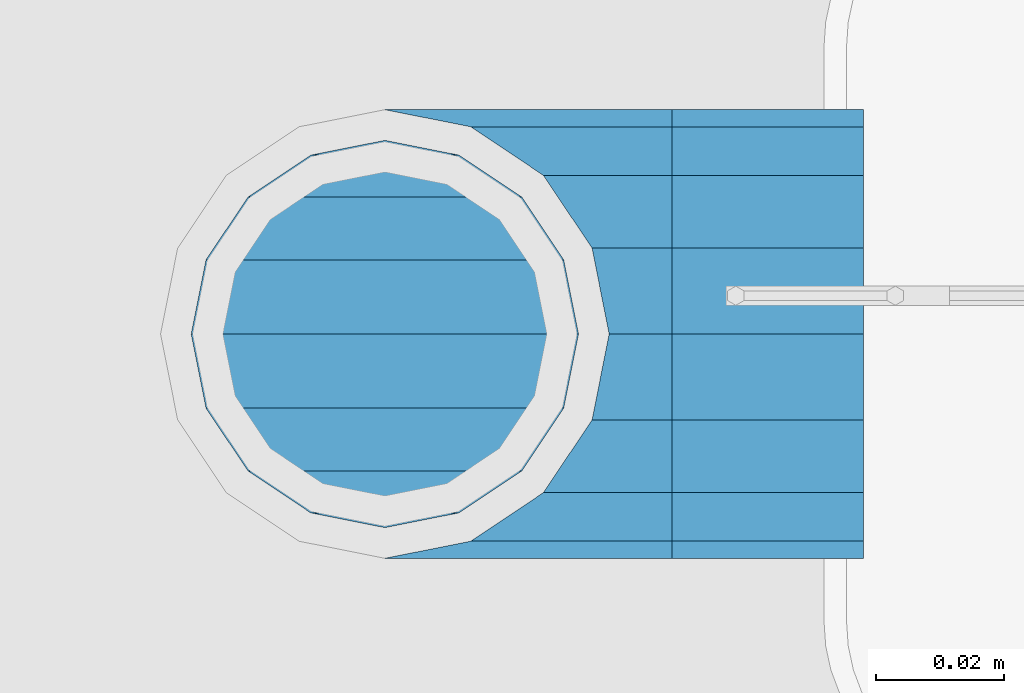
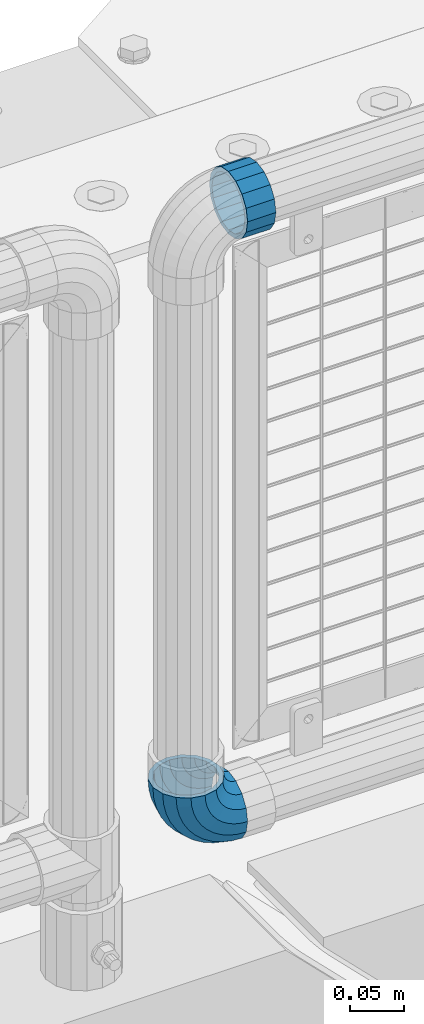
# One storey, part 164 of 242: 1 beam, 1 member.
"""IFC2X3 building model written with IfcOpenShell, lengths in millimetres."""

from ifc_helpers import new_model, si_unit, frame, origin_with_axes, place, context, subcontext, project, spatial, faceted_brep, material, type_object, element, save


model = new_model("IFC2X3")

# Units and contexts
model_context = context("Model", 3, precision=1e-05, world=origin_with_axes())
body_context = subcontext(model_context, "Body", "Model", "MODEL_VIEW")
ifc_project = project(units=[si_unit("LENGTHUNIT", "METRE", prefix="MILLI"), si_unit("AREAUNIT", "SQUARE_METRE"), si_unit("VOLUMEUNIT", "CUBIC_METRE"), si_unit("MASSUNIT", "GRAM", prefix="KILO"), si_unit("TIMEUNIT", "SECOND"), si_unit("PLANEANGLEUNIT", "RADIAN"), si_unit("SOLIDANGLEUNIT", "STERADIAN"), si_unit("THERMODYNAMICTEMPERATUREUNIT", "DEGREE_CELSIUS"), si_unit("LUMINOUSINTENSITYUNIT", "LUMEN")], contexts=[model_context])

# Site, building, storey
site_placement = place(None, origin_with_axes())
site = spatial("IfcSite", under=ifc_project, at=site_placement, CompositionType="ELEMENT")
building_placement = place(site_placement, origin_with_axes())
building = spatial("IfcBuilding", under=site, at=building_placement, Name="Standard", CompositionType="ELEMENT")
storey_placement = place(building_placement, origin_with_axes())
storey = spatial("IfcBuildingStorey", under=building, at=storey_placement, Name="Undefined", CompositionType="ELEMENT", Elevation=0.0)

# Beam
ifc_material = material(Name="Misc_Undefined")
beam_type = type_object("IfcBeamType", PredefinedType="NOTDEFINED")
beam_placement = place(storey_placement, frame((-23710.39, -19335.5, 969.849999999999), z_axis=(0.0, 0.0, 1.0), x_axis=(1.0, 0.0, 0.0)))
element("IfcBeam", 1, at=beam_placement, inside=storey, type_object=beam_type, material=ifc_material, context=body_context, shape_type="Brep", body=[
    faceted_brep([(0.0, -30.3499999999985, 0.0), (0.0, -28.0397438117179, 11.6144421722784), (30.0, -28.0397438117179, 11.6144421722805), (30.0, -30.3499999999985, 0.0), (0.0, -21.46069080901, 21.4606908090136), (30.0, -21.46069080901, 21.4606908090117), (0.0, -11.614442172282, 28.0397438117143), (30.0, -11.614442172282, 28.0397438117176), (0.0, 0.0, 30.3499999999985), (30.0, 0.0, 30.35), (0.0, 11.614442172282, 28.0397438117143), (30.0, 11.614442172282, 28.0397438117176), (0.0, 21.46069080901, 21.4606908090136), (30.0, 21.46069080901, 21.4606908090117), (0.0, 28.0397438117179, 11.6144421722784), (30.0, 28.0397438117179, 11.6144421722805), (0.0, 30.3499999999985, 0.0), (30.0, 30.3499999999985, 0.0), (0.0, 28.0397438117179, -11.6144421722784), (30.0, 28.0397438117179, -11.6144421722805), (0.0, 21.46069080901, -21.4606908090136), (30.0, 21.46069080901, -21.4606908090117), (0.0, 11.614442172282, -28.0397438117143), (30.0, 11.614442172282, -28.0397438117176), (0.0, 0.0, -30.3499999999985), (30.0, 0.0, -30.35), (0.0, -11.614442172282, -28.0397438117143), (30.0, -11.614442172282, -28.0397438117176), (0.0, -21.46069080901, -21.4606908090136), (30.0, -21.46069080901, -21.4606908090117), (0.0, -28.0397438117179, -11.6144421722784), (30.0, -28.0397438117179, -11.6144421722805), (0.0, -35.1500000000015, 0.0), (0.0, -32.4743655677703, -13.4513226476338), (30.0, -32.4743655677703, -13.4513226476329), (30.0, -35.1500000000015, 0.0), (0.0, -24.8548033587067, -24.8548033587067), (30.0, -24.8548033587067, -24.8548033587072), (0.0, -13.4513226476338, -32.4743655677739), (30.0, -13.4513226476338, -32.4743655677718), (0.0, 0.0, -35.1500000000015), (30.0, 0.0, -35.15), (0.0, 13.4513226476338, -32.4743655677739), (30.0, 13.4513226476338, -32.4743655677718), (0.0, 24.8548033587067, -24.8548033587067), (30.0, 24.8548033587067, -24.8548033587072), (0.0, 32.4743655677703, -13.4513226476338), (30.0, 32.4743655677703, -13.4513226476329), (0.0, 35.1500000000015, 0.0), (30.0, 35.1500000000015, 0.0), (0.0, 32.4743655677703, 13.4513226476338), (30.0, 32.4743655677703, 13.4513226476329), (0.0, 24.8548033587067, 24.8548033587067), (30.0, 24.8548033587067, 24.8548033587072), (0.0, 13.4513226476338, 32.4743655677739), (30.0, 13.4513226476338, 32.4743655677718), (0.0, 0.0, 35.1500000000015), (30.0, 0.0, 35.15), (0.0, -13.4513226476338, 32.4743655677739), (30.0, -13.4513226476338, 32.4743655677718), (0.0, -24.8548033587067, 24.8548033587067), (30.0, -24.8548033587067, 24.8548033587072), (0.0, -32.4743655677703, 13.4513226476338), (30.0, -32.4743655677703, 13.4513226476329)], [[[0, 1, 2, 3]], [[1, 4, 5, 2]], [[4, 6, 7, 5]], [[6, 8, 9, 7]], [[8, 10, 11, 9]], [[10, 12, 13, 11]], [[12, 14, 15, 13]], [[14, 16, 17, 15]], [[16, 18, 19, 17]], [[18, 20, 21, 19]], [[20, 22, 23, 21]], [[22, 24, 25, 23]], [[24, 26, 27, 25]], [[26, 28, 29, 27]], [[28, 30, 31, 29]], [[30, 0, 3, 31]], [[32, 33, 34, 35]], [[33, 36, 37, 34]], [[36, 38, 39, 37]], [[38, 40, 41, 39]], [[40, 42, 43, 41]], [[42, 44, 45, 43]], [[44, 46, 47, 45]], [[46, 48, 49, 47]], [[48, 50, 51, 49]], [[50, 52, 53, 51]], [[52, 54, 55, 53]], [[54, 56, 57, 55]], [[56, 58, 59, 57]], [[58, 60, 61, 59]], [[60, 62, 63, 61]], [[62, 32, 35, 63]], [[37, 39, 41, 43, 45, 47, 49, 51, 53, 55, 57, 59, 61, 63, 35, 34], [5, 7, 9, 11, 13, 15, 17, 19, 21, 23, 25, 27, 29, 31, 3, 2]], [[62, 60, 58, 56, 54, 52, 50, 48, 46, 44, 42, 40, 38, 36, 33, 32], [30, 28, 26, 24, 22, 20, 18, 16, 14, 12, 10, 8, 6, 4, 1, 0]]]),
])

# Member
member_type = type_object("IfcMemberType", PredefinedType="NOTDEFINED")
member_placement = place(storey_placement, frame((-23755.39, -19335.5, 343.170000000002), z_axis=(-0.707106781186548, 0.0, -0.707106781186548), x_axis=(0.707106781186548, 0.0, -0.707106781186548)))
element("IfcMember", 2, at=member_placement, inside=storey, type_object=member_type, material=ifc_material, context=body_context, shape_type="Brep", body=[
    faceted_brep([(0.0, -35.1500000000015, 0.0), (9.51152146006643, -32.4743655677703, -9.51152146006643), (13.2759578763398, -32.4743655677703, -6.29638902527768), (5.36946880023243, -35.1500000000015, 4.58595959347804), (17.5749999999971, -24.8548033587067, -17.5749999999971), (19.978755663109, -24.8548033587067, -15.5219987155633), (22.9628441077002, -13.4513226476338, -22.9628441077002), (24.4574219585229, -13.4513226476338, -21.6863540323939), (24.8548033587067, 0.0, -24.8548033587067), (26.0301204183124, 0.0, -23.8509877588003), (22.9628441077002, 13.4513226476338, -22.9628441077002), (24.4574219585229, 13.4513226476338, -21.6863540323939), (17.5749999999971, 24.8548033587067, -17.5749999999971), (19.978755663109, 24.8548033587067, -15.5219987155633), (9.51152146006643, 32.4743655677703, -9.51152146006643), (13.2759578763398, 32.4743655677703, -6.29638902527768), (0.0, 35.1500000000015, 0.0), (5.36946880023243, 35.1500000000015, 4.58595959347804), (-9.51152146007371, 32.4743655677703, 9.51152146007371), (-2.53702027587133, 32.4743655677703, 15.4683082122338), (-17.5750000000007, 24.8548033587067, 17.5750000000007), (-9.23981806264783, 24.8548033587067, 24.6939179025212), (-22.9628441077039, 13.4513226476338, 22.9628441077039), (-13.718484358058, 13.4513226476338, 30.8582732193499), (-24.8548033587103, 0.0, 24.8548033587103), (-15.2911828178512, 0.0, 33.02290694576), (-22.9628441077039, -13.4513226476338, 22.9628441077039), (-13.718484358058, -13.4513226476338, 30.8582732193499), (-17.5750000000007, -24.8548033587067, 17.5750000000007), (-9.23981806264783, -24.8548033587067, 24.6939179025212), (-9.51152146007371, -32.4743655677703, 9.51152146007371), (-2.53702027587133, -32.4743655677703, 15.4683082122338), (0.0, -30.3499999999985, 0.0), (-8.2126508197216, -28.0397438117179, 8.2126508197216), (-1.45732902223972, -28.0397438117179, 13.9822406910389), (5.36946880023243, -30.3499999999985, 4.58595959347804), (-15.1749999999993, -21.46069080901, 15.1750000000029), (-7.24480876131565, -21.46069080901, 21.9480231689959), (-19.827092992, -11.614442172282, 19.827092992), (-11.1118790903529, -11.614442172282, 27.2705888550809), (-21.4606908090136, 0.0, 21.4606908090136), (-12.4698136068437, 0.0, 29.1396253727598), (-19.827092992, 11.614442172282, 19.827092992), (-11.1118790903529, 11.614442172282, 27.2705888550809), (-15.1749999999993, 21.46069080901, 15.1750000000029), (-7.24480876131565, 21.46069080901, 21.9480231689959), (-8.2126508197216, 28.0397438117179, 8.2126508197216), (-1.45732902223972, 28.0397438117179, 13.9822406910389), (0.0, 30.3499999999985, 0.0), (5.36946880023243, 30.3499999999985, 4.58595959347804), (8.21265081971796, 28.0397438117179, -8.21265081971796), (12.1962666227009, 28.0397438117179, -4.81032150407918), (15.1749999999956, 21.46069080901, -15.1749999999956), (17.9837463617769, 21.46069080901, -12.776103982038), (19.8270929919963, 11.614442172282, -19.8270929919963), (21.8508166908177, 11.614442172282, -18.0986696681193), (21.46069080901, 0.0, -21.46069080901), (23.2087512073085, 0.0, -19.9677061858001), (19.8270929919963, -11.614442172282, -19.8270929919963), (21.8508166908177, -11.614442172282, -18.0986696681193), (15.1749999999956, -21.46069080901, -15.1749999999956), (17.9837463617769, -21.46069080901, -12.776103982038), (8.21265081971796, -28.0397438117179, -8.21265081971796), (12.1962666227009, -28.0397438117179, -4.81032150407918), (17.4970053560683, -32.4743655677703, -3.70972780291959), (11.3902326651114, -35.1500000000015, 8.27548843508339), (22.6740772628618, -24.8548033587067, -13.870303514941), (26.1332861179508, -13.4513226476338, -20.6593831546816), (27.3479987309584, 0.0, -23.0433908901377), (26.1332861179508, 13.4513226476338, -20.6593831546816), (22.6740772628618, 24.8548033587067, -13.870303514941), (17.4970053560683, 32.4743655677703, -3.70972780291959), (11.3902326651114, 35.1500000000015, 8.27548843508339), (5.28345997415818, 32.4743655677703, 20.2607046730864), (0.106388067368243, 24.8548033587067, 30.4212803851133), (-3.35282078772798, 13.4513226476338, 37.2103600248483), (-4.56753340073192, 0.0, 39.5943677603045), (-3.35282078772798, -13.4513226476338, 37.2103600248483), (0.106388067368243, -24.8548033587067, 30.4212803851133), (5.28345997415818, -32.4743655677703, 20.2607046730864), (6.11738625912403, -28.0397438117179, 18.6240321853948), (11.3902326651114, -30.3499999999985, 8.27548843508339), (1.6472829199738, -21.46069080901, 27.3971039595017), (-1.3395446405375, -11.614442172282, 33.2590831078942), (-2.38837900198268, 0.0, 35.3175364441995), (-1.3395446405375, 11.614442172282, 33.2590831078942), (1.6472829199738, 21.46069080901, 27.3971039595017), (6.11738625912403, 28.0397438117179, 18.6240321853948), (11.3902326651114, 30.3499999999985, 8.27548843508339), (16.6630790711024, 28.0397438117179, -2.07305531522434), (21.1331824102526, 21.46069080901, -10.8461270893331), (24.1200099707639, 11.614442172282, -16.7081062377274), (25.1688443322091, 0.0, -18.7665595740364), (24.1200099707639, -11.614442172282, -16.7081062377274), (21.1331824102526, -21.46069080901, -10.8461270893331), (16.6630790711024, -28.0397438117179, -2.07305531522434), (22.070727701459, -32.4743655677703, -1.81522997692991), (17.9140404065183, -35.1500000000015, 10.9777380798896), (25.5945970362081, -24.8548033587067, -12.6605846156453), (27.9491712485069, -13.4513226476338, -19.9072189058916), (28.7759877587996, 0.0, -22.4518984678853), (27.9491712485069, 13.4513226476338, -19.9072189058916), (25.5945970362081, 24.8548033587067, -12.6605846156453), (22.070727701459, 32.4743655677703, -1.81522997692991), (17.9140404065183, 35.1500000000015, 10.9777380798896), (13.7573531115813, 32.4743655677703, 23.7707061367073), (10.2334837768321, 24.8548033587067, 34.6160607754227), (7.87890956453339, 13.4513226476338, 41.862695065669), (7.05209305424069, 0.0, 44.4073746276626), (7.87890956453339, -13.4513226476338, 41.862695065669), (10.2334837768321, -24.8548033587067, 34.6160607754227), (13.7573531115813, -32.4743655677703, 23.7707061367073), (14.3249803951003, -28.0397438117179, 22.0237289909674), (17.9140404065183, -30.3499999999985, 10.9777380798896), (11.2823222355109, -21.46069080901, 31.3880679179947), (9.24928305077992, -11.614442172282, 37.6451191472697), (8.53537462723762, 0.0, 39.8423033494473), (9.24928305077992, 11.614442172282, 37.6451191472697), (11.2823222355109, 21.46069080901, 31.3880679179947), (14.3249803951003, 28.0397438117179, 22.0237289909674), (17.9140404065183, 30.3499999999985, 10.9777380798896), (21.50310041794, 28.0397438117179, -0.0682528311899659), (24.5457585775293, 21.46069080901, -9.43259175821731), (26.5787977622604, 11.614442172282, -15.6896429874923), (27.2927061858027, 0.0, -17.8868271896699), (26.5787977622604, -11.614442172282, -15.6896429874923), (24.5457585775293, -21.46069080901, -9.43259175821731), (21.50310041794, -28.0397438117179, -0.0682528311899659), (26.8845046890456, -32.4743655677703, -0.659544371261291), (24.7802542265854, -35.1500000000015, 12.6261701733874), (28.6684020936846, -24.8548033587067, -11.9226293117918), (29.8603642316994, -13.4513226476338, -19.4483820661244), (30.2789256727447, 0.0, -22.0910749985305), (29.8603642316994, 13.4513226476338, -19.4483820661244), (28.6684020936846, 24.8548033587067, -11.9226293117918), (26.8845046890456, 32.4743655677703, -0.659544371261291), (24.7802542265854, 35.1500000000015, 12.6261701733874), (22.6760037641179, 32.4743655677703, 25.911884718038), (20.8921063594826, 24.8548033587067, 37.1749696585684), (19.7001442214641, 13.4513226476338, 44.7007224129011), (19.2815827804188, 0.0, 47.3434153453072), (19.7001442214641, -13.4513226476338, 44.7007224129011), (20.8921063594826, -24.8548033587067, 37.1749696585684), (22.6760037641179, -32.4743655677703, 25.911884718038), (22.963355178621, -28.0397438117179, 24.0976192894668), (24.7802542265854, -30.3499999999985, 12.6261701733874), (21.4230625404816, -21.46069080901, 33.8226442665673), (20.3938719035323, -11.614442172282, 40.3206982094944), (20.032468212612, 0.0, 42.6025113104497), (20.3938719035323, 11.614442172282, 40.3206982094944), (21.4230625404816, 21.46069080901, 33.8226442665673), (22.963355178621, 28.0397438117179, 24.0976192894668), (24.7802542265854, 30.3499999999985, 12.6261701733874), (26.5971532745461, 28.0397438117179, 1.15472105730987), (28.1374459126855, 21.46069080901, -8.5703039197906), (29.1666365496349, 11.614442172282, -15.0683578627177), (29.5280402405515, 0.0, -17.350170963673), (29.1666365496349, -11.614442172282, -15.0683578627177), (28.1374459126855, -21.46069080901, -8.5703039197906), (26.5971532745461, -28.0397438117179, 1.15472105730987), (31.8198051533909, -32.4743655677703, -0.271127801024704), (31.8198051533909, -35.1500000000015, 13.1801948466091), (31.8198051533946, -24.8548033587067, -11.6746085121031), (31.8198051533909, -13.4513226476338, -19.2941707211648), (31.8198051533909, 0.0, -21.9698051533924), (31.8198051533909, 13.4513226476338, -19.2941707211648), (31.8198051533946, 24.8548033587067, -11.6746085121031), (31.8198051533909, 32.4743655677703, -0.271127801024704), (31.8198051533909, 35.1500000000015, 13.1801948466091), (31.8198051533909, 32.4743655677703, 26.6315174942411), (31.8198051533909, 24.8548033587067, 38.0349982053158), (31.8198051533909, 13.4513226476338, 45.6545604143812), (31.8198051533946, 0.0, 48.3301948466051), (31.8198051533909, -13.4513226476338, 45.6545604143812), (31.8198051533909, -24.8548033587067, 38.0349982053158), (31.8198051533909, -32.4743655677703, 26.6315174942411), (31.8198051533909, -28.0397438117179, 24.7946370188874), (31.8198051533909, -30.3499999999985, 13.1801948466091), (31.8198051533946, -21.46069080901, 34.6408856556172), (31.8198051533946, -11.614442172282, 41.2199386583234), (31.8198051533909, 0.0, 43.5301948466076), (31.8198051533946, 11.614442172282, 41.2199386583234), (31.8198051533946, 21.46069080901, 34.6408856556172), (31.8198051533909, 28.0397438117179, 24.7946370188874), (31.8198051533909, 30.3499999999985, 13.1801948466091), (31.8198051533946, 28.0397438117179, 1.56575267432527), (31.8198051533909, 21.46069080901, -8.28049596240453), (31.8198051533946, 11.614442172282, -14.8595489651107), (31.8198051533909, 0.0, -17.1698051533913), (31.8198051533946, -11.614442172282, -14.8595489651107), (31.8198051533909, -21.46069080901, -8.28049596240453), (31.8198051533946, -28.0397438117179, 1.56575267432527), (36.7551056177363, -32.4743655677703, -0.659544371261291), (38.8593560802037, -35.1500000000015, 12.6261701733874), (34.9712082131009, -24.8548033587067, -11.9226293117899), (33.7792460750898, -13.4513226476338, -19.4483820661244), (33.3606846340372, 0.0, -22.0910749985305), (33.7792460750898, 13.4513226476338, -19.4483820661244), (34.9712082131009, 24.8548033587067, -11.9226293117899), (36.7551056177363, 32.4743655677703, -0.659544371261291), (38.8593560802037, 35.1500000000015, 12.6261701733874), (40.9636065426712, 32.4743655677703, 25.911884718038), (42.7475039473029, 24.8548033587067, 37.1749696585703), (43.9394660853177, 13.4513226476338, 44.7007224129011), (44.3580275263666, 0.0, 47.3434153453054), (43.9394660853177, -13.4513226476338, 44.7007224129011), (42.7475039473029, -24.8548033587067, 37.1749696585703), (40.9636065426712, -32.4743655677703, 25.911884718038), (40.6762551281645, -28.0397438117179, 24.097619289465), (38.8593560802037, -30.3499999999985, 12.6261701733874), (42.2165477663038, -21.46069080901, 33.8226442665655), (43.2457384032568, -11.614442172282, 40.3206982094944), (43.6071420941771, 0.0, 42.6025113104533), (43.2457384032568, 11.614442172282, 40.3206982094944), (42.2165477663038, 21.46069080901, 33.8226442665655), (40.6762551281645, 28.0397438117179, 24.097619289465), (38.8593560802037, 30.3499999999985, 12.6261701733874), (37.042457032243, 28.0397438117179, 1.15472105730987), (35.5021643941, 21.46069080901, -8.5703039197906), (34.4729737571543, 11.614442172282, -15.0683578627231), (34.1115700662303, 0.0, -17.350170963673), (34.4729737571543, -11.614442172282, -15.0683578627231), (35.5021643941, -21.46069080901, -8.5703039197906), (37.042457032243, -28.0397438117179, 1.15472105730987), (41.5688826053265, -32.4743655677703, -1.81522997693173), (45.7255699002671, -35.1500000000015, 10.9777380798896), (38.0450132705773, -24.8548033587067, -12.6605846156435), (35.6904390582749, -13.4513226476338, -19.9072189058897), (34.8636225479822, 0.0, -22.4518984678834), (35.6904390582749, 13.4513226476338, -19.9072189058897), (38.0450132705773, 24.8548033587067, -12.6605846156435), (41.5688826053265, 32.4743655677703, -1.81522997693173), (45.7255699002671, 35.1500000000015, 10.9777380798896), (49.8822571952041, 32.4743655677703, 23.7707061367091), (53.4061265299533, 24.8548033587067, 34.6160607754209), (55.7607007422557, 13.4513226476338, 41.8626950656671), (56.5875172525448, 0.0, 44.4073746276645), (55.7607007422557, -13.4513226476338, 41.8626950656671), (53.4061265299533, -24.8548033587067, 34.6160607754209), (49.8822571952041, -32.4743655677703, 23.7707061367091), (49.3146299116852, -28.0397438117179, 22.0237289909692), (45.7255699002671, -30.3499999999985, 10.9777380798896), (52.3572880712782, -21.46069080901, 31.3880679179947), (54.3903272560092, -11.614442172282, 37.6451191472679), (55.1042356795442, 0.0, 39.8423033494473), (54.3903272560092, 11.614442172282, 37.6451191472679), (52.3572880712782, 21.46069080901, 31.3880679179947), (49.3146299116852, 28.0397438117179, 22.0237289909692), (45.7255699002671, 30.3499999999985, 10.9777380798896), (42.1365098888455, 28.0397438117179, -0.0682528311917849), (39.0938517292525, 21.46069080901, -9.43259175821731), (37.0608125445215, 11.614442172282, -15.6896429874905), (36.3469041209864, 0.0, -17.8868271896699), (37.0608125445215, -11.614442172282, -15.6896429874905), (39.0938517292525, -21.46069080901, -9.43259175821731), (42.1365098888455, -28.0397438117179, -0.0682528311917849), (46.1426049507172, -32.4743655677703, -3.70972780292141), (52.2493776416704, -35.1500000000015, 8.27548843508339), (40.9655330439236, -24.8548033587067, -13.8703035149429), (37.5063241888347, -13.4513226476338, -20.6593831546797), (36.2916115758235, 0.0, -23.0433908901359), (37.5063241888347, 13.4513226476338, -20.6593831546797), (40.9655330439236, 24.8548033587067, -13.8703035149429), (46.1426049507172, 32.4743655677703, -3.70972780292141), (52.2493776416704, 35.1500000000015, 8.27548843508339), (58.3561503326309, 32.4743655677703, 20.26070467309), (63.5332222394209, 24.8548033587067, 30.4212803851133), (66.9924310945098, 13.4513226476338, 37.2103600248465), (68.2071437075174, 0.0, 39.5943677603027), (66.9924310945098, -13.4513226476338, 37.2103600248465), (63.5332222394209, -24.8548033587067, 30.4212803851133), (58.3561503326309, -32.4743655677703, 20.26070467309), (57.5222240476614, -28.0397438117179, 18.6240321853948), (52.2493776416704, -30.3499999999985, 8.27548843508339), (61.9923273868117, -21.46069080901, 27.3971039595035), (64.9791549473193, -11.614442172282, 33.259083107896), (66.0279893087682, 0.0, 35.3175364442013), (64.9791549473193, 11.614442172282, 33.259083107896), (61.9923273868117, 21.46069080901, 27.3971039595035), (57.5222240476614, 28.0397438117179, 18.6240321853948), (52.2493776416704, 30.3499999999985, 8.27548843508339), (46.9765312356831, 28.0397438117179, -2.07305531522616), (42.5064278965328, 21.46069080901, -10.8461270893349), (39.5196003360215, 11.614442172282, -16.7081062377292), (38.4707659745764, 0.0, -18.7665595740327), (39.5196003360215, -11.614442172282, -16.7081062377292), (42.5064278965328, -21.46069080901, -10.8461270893349), (46.9765312356831, -28.0397438117179, -2.07305531522616), (50.3636524304493, -32.4743655677703, -6.29638902527404), (58.2701415065567, -35.1500000000015, 4.58595959347986), (43.6608546436801, -24.8548033587067, -15.5219987155633), (39.1821883482626, -13.4513226476338, -21.686354032392), (37.609489888473, 0.0, -23.8509877587985), (39.1821883482626, 13.4513226476338, -21.686354032392), (43.6608546436801, 24.8548033587067, -15.5219987155633), (50.3636524304493, 32.4743655677703, -6.29638902527404), (58.2701415065567, 35.1500000000015, 4.58595959347986), (66.1766305826604, 32.4743655677703, 15.4683082122356), (72.8794283694297, 24.8548033587067, 24.6939179025212), (77.3580946648435, 13.4513226476338, 30.8582732193518), (78.9307931246331, 0.0, 33.02290694576), (77.3580946648435, -13.4513226476338, 30.8582732193518), (72.8794283694297, -24.8548033587067, 24.6939179025212), (66.1766305826604, -32.4743655677703, 15.4683082122356), (65.0969393290252, -28.0397438117179, 13.9822406910407), (58.2701415065567, -30.3499999999985, 4.58595959347986), (70.8844190681011, -21.46069080901, 21.9480231689959), (74.751489397142, -11.614442172282, 27.270588855079), (76.1094239136328, 0.0, 29.139625372758), (74.751489397142, 11.614442172282, 27.270588855079), (70.8844190681011, 21.46069080901, 21.9480231689959), (65.0969393290252, 28.0397438117179, 13.9822406910407), (58.2701415065567, 30.3499999999985, 4.58595959347986), (51.4433436840845, 28.0397438117179, -4.81032150407918), (45.655863945005, 21.46069080901, -12.7761039820361), (41.7887936159677, 11.614442172282, -18.0986696681175), (40.4308590994769, 0.0, -19.9677061858019), (41.7887936159677, -11.614442172282, -18.0986696681175), (45.655863945005, -21.46069080901, -12.7761039820361), (51.4433436840845, -28.0397438117179, -4.81032150407918), (54.1280888467154, -32.4743655677703, -9.51152146006643), (63.6396103067855, -35.1500000000015, 3.63797880709171e-12), (46.0646103067847, -24.8548033587067, -17.5749999999971), (40.6767661990853, -13.4513226476338, -22.9628441077002), (38.7848069480788, 0.0, -24.8548033587049), (40.6767661990853, 13.4513226476338, -22.9628441077002), (46.0646103067847, 24.8548033587067, -17.5749999999971), (54.1280888467154, 32.4743655677703, -9.51152146006643), (63.6396103067855, 35.1500000000015, 3.63797880709171e-12), (73.1511317668555, 32.4743655677703, 9.51152146007189), (81.2146103067862, 24.8548033587067, 17.5750000000025), (86.6024544144893, 13.4513226476338, 22.9628441077057), (88.4944136654922, 0.0, 24.8548033587103), (86.6024544144893, -13.4513226476338, 22.9628441077057), (81.2146103067862, -24.8548033587067, 17.5750000000025), (73.1511317668555, -32.4743655677703, 9.51152146007189), (71.8522611265034, -28.0397438117179, 8.2126508197216), (63.6396103067855, -30.3499999999985, 3.63797880709171e-12), (78.8146103067847, -21.46069080901, 15.1750000000029), (83.4667032987854, -11.614442172282, 19.8270929920018), (85.1003011157991, 0.0, 21.4606908090154), (83.4667032987854, 11.614442172282, 19.8270929920018), (78.8146103067847, 21.46069080901, 15.1750000000029), (71.8522611265034, 28.0397438117179, 8.2126508197216), (63.6396103067855, 30.3499999999985, 3.63797880709171e-12), (55.4269594870675, 28.0397438117179, -8.21265081971615), (48.4646103067862, 21.46069080901, -15.1749999999975), (43.8125173147855, 11.614442172282, -19.8270929919963), (42.1789194977755, 0.0, -21.4606908090082), (43.8125173147855, -11.614442172282, -19.8270929919963), (48.4646103067862, -21.46069080901, -15.1749999999975), (55.4269594870675, -28.0397438117179, -8.21265081971615)], [[[0, 1, 2, 3]], [[1, 4, 5, 2]], [[4, 6, 7, 5]], [[6, 8, 9, 7]], [[8, 10, 11, 9]], [[10, 12, 13, 11]], [[12, 14, 15, 13]], [[14, 16, 17, 15]], [[16, 18, 19, 17]], [[18, 20, 21, 19]], [[20, 22, 23, 21]], [[22, 24, 25, 23]], [[24, 26, 27, 25]], [[26, 28, 29, 27]], [[28, 30, 31, 29]], [[30, 0, 3, 31]], [[32, 33, 34, 35]], [[33, 36, 37, 34]], [[36, 38, 39, 37]], [[38, 40, 41, 39]], [[40, 42, 43, 41]], [[42, 44, 45, 43]], [[44, 46, 47, 45]], [[46, 48, 49, 47]], [[48, 50, 51, 49]], [[50, 52, 53, 51]], [[52, 54, 55, 53]], [[54, 56, 57, 55]], [[56, 58, 59, 57]], [[58, 60, 61, 59]], [[60, 62, 63, 61]], [[62, 32, 35, 63]], [[30, 28, 26, 24, 22, 20, 18, 16, 14, 12, 10, 8, 6, 4, 1, 0], [62, 60, 58, 56, 54, 52, 50, 48, 46, 44, 42, 40, 38, 36, 33, 32]], [[3, 2, 64, 65]], [[2, 5, 66, 64]], [[5, 7, 67, 66]], [[7, 9, 68, 67]], [[9, 11, 69, 68]], [[11, 13, 70, 69]], [[13, 15, 71, 70]], [[15, 17, 72, 71]], [[17, 19, 73, 72]], [[19, 21, 74, 73]], [[21, 23, 75, 74]], [[23, 25, 76, 75]], [[25, 27, 77, 76]], [[27, 29, 78, 77]], [[29, 31, 79, 78]], [[31, 3, 65, 79]], [[35, 34, 80, 81]], [[34, 37, 82, 80]], [[37, 39, 83, 82]], [[39, 41, 84, 83]], [[41, 43, 85, 84]], [[43, 45, 86, 85]], [[45, 47, 87, 86]], [[47, 49, 88, 87]], [[49, 51, 89, 88]], [[51, 53, 90, 89]], [[53, 55, 91, 90]], [[55, 57, 92, 91]], [[57, 59, 93, 92]], [[59, 61, 94, 93]], [[61, 63, 95, 94]], [[63, 35, 81, 95]], [[65, 64, 96, 97]], [[64, 66, 98, 96]], [[66, 67, 99, 98]], [[67, 68, 100, 99]], [[68, 69, 101, 100]], [[69, 70, 102, 101]], [[70, 71, 103, 102]], [[71, 72, 104, 103]], [[72, 73, 105, 104]], [[73, 74, 106, 105]], [[74, 75, 107, 106]], [[75, 76, 108, 107]], [[76, 77, 109, 108]], [[77, 78, 110, 109]], [[78, 79, 111, 110]], [[79, 65, 97, 111]], [[81, 80, 112, 113]], [[80, 82, 114, 112]], [[82, 83, 115, 114]], [[83, 84, 116, 115]], [[84, 85, 117, 116]], [[85, 86, 118, 117]], [[86, 87, 119, 118]], [[87, 88, 120, 119]], [[88, 89, 121, 120]], [[89, 90, 122, 121]], [[90, 91, 123, 122]], [[91, 92, 124, 123]], [[92, 93, 125, 124]], [[93, 94, 126, 125]], [[94, 95, 127, 126]], [[95, 81, 113, 127]], [[97, 96, 128, 129]], [[96, 98, 130, 128]], [[98, 99, 131, 130]], [[99, 100, 132, 131]], [[100, 101, 133, 132]], [[101, 102, 134, 133]], [[102, 103, 135, 134]], [[103, 104, 136, 135]], [[104, 105, 137, 136]], [[105, 106, 138, 137]], [[106, 107, 139, 138]], [[107, 108, 140, 139]], [[108, 109, 141, 140]], [[109, 110, 142, 141]], [[110, 111, 143, 142]], [[111, 97, 129, 143]], [[113, 112, 144, 145]], [[112, 114, 146, 144]], [[114, 115, 147, 146]], [[115, 116, 148, 147]], [[116, 117, 149, 148]], [[117, 118, 150, 149]], [[118, 119, 151, 150]], [[119, 120, 152, 151]], [[120, 121, 153, 152]], [[121, 122, 154, 153]], [[122, 123, 155, 154]], [[123, 124, 156, 155]], [[124, 125, 157, 156]], [[125, 126, 158, 157]], [[126, 127, 159, 158]], [[127, 113, 145, 159]], [[129, 128, 160, 161]], [[128, 130, 162, 160]], [[130, 131, 163, 162]], [[131, 132, 164, 163]], [[132, 133, 165, 164]], [[133, 134, 166, 165]], [[134, 135, 167, 166]], [[135, 136, 168, 167]], [[136, 137, 169, 168]], [[137, 138, 170, 169]], [[138, 139, 171, 170]], [[139, 140, 172, 171]], [[140, 141, 173, 172]], [[141, 142, 174, 173]], [[142, 143, 175, 174]], [[143, 129, 161, 175]], [[145, 144, 176, 177]], [[144, 146, 178, 176]], [[146, 147, 179, 178]], [[147, 148, 180, 179]], [[148, 149, 181, 180]], [[149, 150, 182, 181]], [[150, 151, 183, 182]], [[151, 152, 184, 183]], [[152, 153, 185, 184]], [[153, 154, 186, 185]], [[154, 155, 187, 186]], [[155, 156, 188, 187]], [[156, 157, 189, 188]], [[157, 158, 190, 189]], [[158, 159, 191, 190]], [[159, 145, 177, 191]], [[161, 160, 192, 193]], [[160, 162, 194, 192]], [[162, 163, 195, 194]], [[163, 164, 196, 195]], [[164, 165, 197, 196]], [[165, 166, 198, 197]], [[166, 167, 199, 198]], [[167, 168, 200, 199]], [[168, 169, 201, 200]], [[169, 170, 202, 201]], [[170, 171, 203, 202]], [[171, 172, 204, 203]], [[172, 173, 205, 204]], [[173, 174, 206, 205]], [[174, 175, 207, 206]], [[175, 161, 193, 207]], [[177, 176, 208, 209]], [[176, 178, 210, 208]], [[178, 179, 211, 210]], [[179, 180, 212, 211]], [[180, 181, 213, 212]], [[181, 182, 214, 213]], [[182, 183, 215, 214]], [[183, 184, 216, 215]], [[184, 185, 217, 216]], [[185, 186, 218, 217]], [[186, 187, 219, 218]], [[187, 188, 220, 219]], [[188, 189, 221, 220]], [[189, 190, 222, 221]], [[190, 191, 223, 222]], [[191, 177, 209, 223]], [[193, 192, 224, 225]], [[192, 194, 226, 224]], [[194, 195, 227, 226]], [[195, 196, 228, 227]], [[196, 197, 229, 228]], [[197, 198, 230, 229]], [[198, 199, 231, 230]], [[199, 200, 232, 231]], [[200, 201, 233, 232]], [[201, 202, 234, 233]], [[202, 203, 235, 234]], [[203, 204, 236, 235]], [[204, 205, 237, 236]], [[205, 206, 238, 237]], [[206, 207, 239, 238]], [[207, 193, 225, 239]], [[209, 208, 240, 241]], [[208, 210, 242, 240]], [[210, 211, 243, 242]], [[211, 212, 244, 243]], [[212, 213, 245, 244]], [[213, 214, 246, 245]], [[214, 215, 247, 246]], [[215, 216, 248, 247]], [[216, 217, 249, 248]], [[217, 218, 250, 249]], [[218, 219, 251, 250]], [[219, 220, 252, 251]], [[220, 221, 253, 252]], [[221, 222, 254, 253]], [[222, 223, 255, 254]], [[223, 209, 241, 255]], [[225, 224, 256, 257]], [[224, 226, 258, 256]], [[226, 227, 259, 258]], [[227, 228, 260, 259]], [[228, 229, 261, 260]], [[229, 230, 262, 261]], [[230, 231, 263, 262]], [[231, 232, 264, 263]], [[232, 233, 265, 264]], [[233, 234, 266, 265]], [[234, 235, 267, 266]], [[235, 236, 268, 267]], [[236, 237, 269, 268]], [[237, 238, 270, 269]], [[238, 239, 271, 270]], [[239, 225, 257, 271]], [[241, 240, 272, 273]], [[240, 242, 274, 272]], [[242, 243, 275, 274]], [[243, 244, 276, 275]], [[244, 245, 277, 276]], [[245, 246, 278, 277]], [[246, 247, 279, 278]], [[247, 248, 280, 279]], [[248, 249, 281, 280]], [[249, 250, 282, 281]], [[250, 251, 283, 282]], [[251, 252, 284, 283]], [[252, 253, 285, 284]], [[253, 254, 286, 285]], [[254, 255, 287, 286]], [[255, 241, 273, 287]], [[257, 256, 288, 289]], [[256, 258, 290, 288]], [[258, 259, 291, 290]], [[259, 260, 292, 291]], [[260, 261, 293, 292]], [[261, 262, 294, 293]], [[262, 263, 295, 294]], [[263, 264, 296, 295]], [[264, 265, 297, 296]], [[265, 266, 298, 297]], [[266, 267, 299, 298]], [[267, 268, 300, 299]], [[268, 269, 301, 300]], [[269, 270, 302, 301]], [[270, 271, 303, 302]], [[271, 257, 289, 303]], [[273, 272, 304, 305]], [[272, 274, 306, 304]], [[274, 275, 307, 306]], [[275, 276, 308, 307]], [[276, 277, 309, 308]], [[277, 278, 310, 309]], [[278, 279, 311, 310]], [[279, 280, 312, 311]], [[280, 281, 313, 312]], [[281, 282, 314, 313]], [[282, 283, 315, 314]], [[283, 284, 316, 315]], [[284, 285, 317, 316]], [[285, 286, 318, 317]], [[286, 287, 319, 318]], [[287, 273, 305, 319]], [[289, 288, 320, 321]], [[288, 290, 322, 320]], [[290, 291, 323, 322]], [[291, 292, 324, 323]], [[292, 293, 325, 324]], [[293, 294, 326, 325]], [[294, 295, 327, 326]], [[295, 296, 328, 327]], [[296, 297, 329, 328]], [[297, 298, 330, 329]], [[298, 299, 331, 330]], [[299, 300, 332, 331]], [[300, 301, 333, 332]], [[301, 302, 334, 333]], [[302, 303, 335, 334]], [[303, 289, 321, 335]], [[305, 304, 336, 337]], [[304, 306, 338, 336]], [[306, 307, 339, 338]], [[307, 308, 340, 339]], [[308, 309, 341, 340]], [[309, 310, 342, 341]], [[310, 311, 343, 342]], [[311, 312, 344, 343]], [[312, 313, 345, 344]], [[313, 314, 346, 345]], [[314, 315, 347, 346]], [[315, 316, 348, 347]], [[316, 317, 349, 348]], [[317, 318, 350, 349]], [[318, 319, 351, 350]], [[319, 305, 337, 351]], [[322, 323, 324, 325, 326, 327, 328, 329, 330, 331, 332, 333, 334, 335, 321, 320], [338, 339, 340, 341, 342, 343, 344, 345, 346, 347, 348, 349, 350, 351, 337, 336]]]),
])

save(model, "model.ifc")
